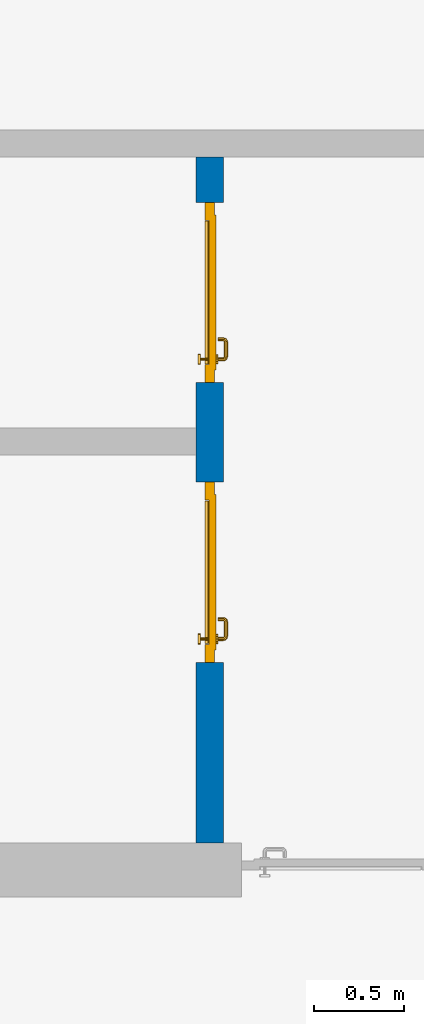
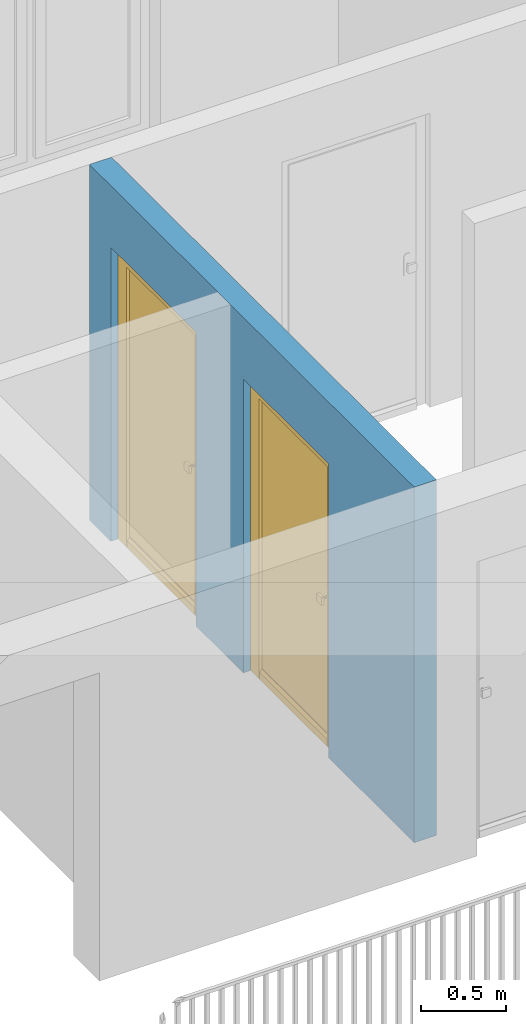
# One storey, part 18 of 54: 2 doors, 1 wall, 2 openings.
"""IFC4 building model written with IfcOpenShell, lengths in metres."""

from ifc_helpers import new_model, entity, si_unit, converted_unit, derived_unit, direction, frame, origin_with_axes, place, context, subcontext, project, spatial, polygons, source, transform, mapped, material, type_object, element, fill, save


model = new_model("IFC4")

# Units and contexts
model_context = context("Model", 3, precision=1e-05, world=origin_with_axes(), true_north=direction((0.0, 1.0)))
body_context = subcontext(model_context, "Body", "Model", "MODEL_VIEW")
ifc_project = project(units=[si_unit("LENGTHUNIT", "METRE"), si_unit("AREAUNIT", "SQUARE_METRE"), si_unit("VOLUMEUNIT", "CUBIC_METRE"), converted_unit("PLANEANGLEUNIT", "DEGREE", entity("IfcPlaneAngleMeasure", 0.0174532925199), si_unit("PLANEANGLEUNIT", "RADIAN"), dimensions=[0, 0, 0, 0, 0, 0, 0]), converted_unit("TIMEUNIT", "Year", entity("IfcTimeMeasure", 31556926.0), si_unit("TIMEUNIT", "SECOND"), dimensions=[0, 0, 1, 0, 0, 0, 0]), si_unit("MASSUNIT", "GRAM", prefix="KILO"), si_unit("THERMODYNAMICTEMPERATUREUNIT", "DEGREE_CELSIUS"), si_unit("LUMINOUSINTENSITYUNIT", "LUMEN"), si_unit("ENERGYUNIT", "JOULE", prefix="MEGA"), derived_unit("THERMALCONDUCTANCEUNIT", [(si_unit("POWERUNIT", "WATT"), 1), (si_unit("LENGTHUNIT", "METRE"), -1), (si_unit("THERMODYNAMICTEMPERATUREUNIT", "KELVIN"), -1)]), derived_unit("SPECIFICHEATCAPACITYUNIT", [(si_unit("ENERGYUNIT", "JOULE"), 1), (si_unit("MASSUNIT", "GRAM", prefix="KILO"), -1), (si_unit("THERMODYNAMICTEMPERATUREUNIT", "KELVIN"), -1)]), derived_unit("MASSDENSITYUNIT", [(si_unit("MASSUNIT", "GRAM", prefix="KILO"), 1), (si_unit("VOLUMEUNIT", "CUBIC_METRE"), -1)])], contexts=[model_context])

# Site, building, storey
site_placement = place(None, origin_with_axes())
site = spatial("IfcSite", under=ifc_project, at=site_placement, CompositionType="ELEMENT")
building_placement = place(site_placement, origin_with_axes())
building = spatial("IfcBuilding", under=site, at=building_placement, CompositionType="ELEMENT")
storey_placement = place(building_placement, frame((0.0, 0.0, 6.29), z_axis=(0.0, 0.0, 1.0), x_axis=(1.0, 0.0, 0.0)))
storey = spatial("IfcBuildingStorey", under=building, at=storey_placement, Name="2. Geschoss", CompositionType="ELEMENT", Elevation=6.29)

# Wall, openings, doors
ifc_material = material()
wall_type = type_object("IfcWallType", Name="150", PredefinedType="NOTDEFINED")
wall_placement = place(storey_placement, frame((1.3378006196, 1.37118776896, 0.0), z_axis=(0.0, 0.0, 1.0), x_axis=(0.0, 1.0, 0.0)))
wall = element("IfcWall", 1, at=wall_placement, inside=storey, type_object=wall_type, material=ifc_material, Name="Wand-002", PredefinedType="NOTDEFINED", context=body_context, shape_type="Tessellation", body=[
    polygons([(1.3, 0.0, 0.0), (1.3, 0.0, 2.1), (2.3, 0.0, 2.1), (2.3, 0.0, 0.0), (2.85, 0.0, 0.0), (2.85, 0.0, 2.1), (3.85, 0.0, 2.1), (3.85, 0.0, 0.0), (4.1, 0.0, 0.0), (4.1, 0.0, 2.54), (0.3, 0.0, 2.54), (0.3, 0.0, 0.0), (1.3, 0.1, 0.0), (1.3, 0.15, 0.0), (1.3, 0.15, 2.1), (2.3, 0.15, 2.1), (2.3, 0.1, 0.0), (2.3, 0.15, 0.0), (2.85, 0.15, 0.0), (2.85, 0.15, 2.1), (3.85, 0.15, 2.1), (3.85, 0.15, 0.0), (4.1, 0.15, 0.0), (4.1, 0.15, 2.54), (0.3, 0.15, 2.54), (0.3, 0.15, 0.0)], [[[1, 2, 3, 4, 5, 6, 7, 8, 9, 10, 11, 12]], [[2, 1, 13, 14, 15]], [[3, 2, 15, 16]], [[17, 4, 3, 16, 18]], [[4, 17, 18, 19, 5]], [[19, 20, 6, 5]], [[20, 21, 7, 6]], [[21, 22, 8, 7]], [[23, 9, 8, 22]], [[23, 24, 10, 9]], [[25, 11, 10, 24]], [[12, 11, 25, 26]], [[13, 1, 12, 26, 14]], [[19, 18, 16, 15, 14, 26, 25, 24, 23, 22, 21, 20]]], closed=True),
])
opening_1_placement = place(wall_placement, frame((3.35, 0.0, 0.0), z_axis=(0.0, 0.0, 1.0), x_axis=(1.0, 0.0, 0.0)))
opening_1 = element("IfcOpeningElement", 2, at=opening_1_placement, cuts=wall, context=body_context, identifier="Reference", shape_type="Tessellation", body=[
    polygons([(-0.5, 0.1, 0.0), (-0.5, 0.1, 2.1), (-0.5, 0.151, 2.1), (-0.5, 0.151, 0.0), (-0.5, -0.001, 0.0), (-0.5, -0.001, 2.1), (0.5, 0.1, 2.1), (0.5, 0.151, 2.1), (0.5, -0.001, 2.1), (0.5, 0.151, 0.0), (0.5, 0.1, 0.0), (0.5, -0.001, 0.0)], [[[1, 2, 3, 4]], [[2, 1, 5, 6]], [[7, 8, 3, 2, 6, 9]], [[8, 10, 4, 3]], [[1, 4, 10, 11, 12, 5]], [[6, 5, 12, 9]], [[7, 11, 10, 8]], [[11, 7, 9, 12]]], closed=True),
])
opening_2_placement = place(wall_placement, frame((1.8, 0.0, 0.0), z_axis=(0.0, 0.0, 1.0), x_axis=(1.0, 0.0, 0.0)))
opening_2 = element("IfcOpeningElement", 3, at=opening_2_placement, cuts=wall, context=body_context, identifier="Reference", shape_type="Tessellation", body=[
    polygons([(-0.5, 0.1, 0.0), (-0.5, 0.1, 2.1), (-0.5, 0.151, 2.1), (-0.5, 0.151, 0.0), (-0.5, -0.001, 0.0), (-0.5, -0.001, 2.1), (0.5, 0.1, 2.1), (0.5, 0.151, 2.1), (0.5, -0.001, 2.1), (0.5, 0.151, 0.0), (0.5, 0.1, 0.0), (0.5, -0.001, 0.0)], [[[1, 2, 3, 4]], [[2, 1, 5, 6]], [[7, 8, 3, 2, 6, 9]], [[8, 10, 4, 3]], [[1, 4, 10, 11, 12, 5]], [[6, 5, 12, 9]], [[7, 11, 10, 8]], [[11, 7, 9, 12]]], closed=True),
])
door_type = type_object("IfcDoorType", Name="Eingang 01 1-Fl 26", OperationType="SINGLE_SWING_LEFT", PredefinedType="DOOR")
shared_shape = source(origin_with_axes(), body_context, "Body", "Tessellation", [
    polygons([(-0.5, -0.05, 0.0), (-0.5, -0.05, 2.1), (-0.5, -0.03, 2.1), (-0.5, -0.03, 0.0), (-0.4, -0.05, 0.0), (-0.4, -0.05, 2.0), (-0.1301, -0.05, 2.0), (-0.0001, -0.05, 2.0), (0.4, -0.05, 2.0), (0.4, -0.05, 0.0), (0.5, -0.05, 0.0), (0.5, -0.05, 2.1), (0.5, -0.03, 2.1), (0.5, -0.03, 0.0), (0.4, -0.03, 0.0), (0.4, -0.03, 2.0), (-0.0001, -0.03, 2.0), (-0.1301, -0.03, 2.0), (-0.4, -0.03, 2.0), (-0.4, -0.03, 0.0)], [[[1, 2, 3, 4]], [[1, 5, 6, 7, 8, 9, 10, 11, 12, 2]], [[2, 12, 13, 3]], [[4, 3, 13, 14, 15, 16, 17, 18, 19, 20]], [[5, 1, 4, 20]], [[6, 5, 20, 19]], [[7, 6, 19, 18]], [[8, 7, 18, 17]], [[9, 8, 17, 16]], [[10, 9, 16, 15]], [[11, 10, 15, 14]], [[12, 11, 14, 13]]], closed=True),
    polygons([(-0.5, -0.03, 0.0), (-0.5, -0.03, 2.1), (-0.5, 0.0, 2.1), (-0.5, 0.0, 0.0), (-0.43, -0.03, 0.0), (-0.43, -0.03, 2.03), (-0.1001, -0.03, 2.03), (-0.0301, -0.03, 2.03), (0.43, -0.03, 2.03), (0.43, -0.03, 0.0), (0.5, -0.03, 0.0), (0.5, -0.03, 2.1), (0.5, 0.0, 2.1), (0.5, 0.0, 0.0), (0.43, 0.0, 0.0), (0.43, 0.0, 2.03), (-0.0301, 0.0, 2.03), (-0.1001, 0.0, 2.03), (-0.43, 0.0, 2.03), (-0.43, 0.0, 0.0)], [[[1, 2, 3, 4]], [[1, 5, 6, 7, 8, 9, 10, 11, 12, 2]], [[2, 12, 13, 3]], [[4, 3, 13, 14, 15, 16, 17, 18, 19, 20]], [[5, 1, 4, 20]], [[6, 5, 20, 19]], [[7, 6, 19, 18]], [[8, 7, 18, 17]], [[9, 8, 17, 16]], [[10, 9, 16, 15]], [[11, 10, 15, 14]], [[12, 11, 14, 13]]], closed=True),
    polygons([(-0.43, 0.01, 0.0), (-0.43, 0.01, 2.03), (0.43, 0.01, 2.03), (0.43, 0.01, 0.0), (-0.43, -0.03, 0.0), (-0.43, -0.03, 2.03), (0.43, -0.03, 2.03), (0.43, -0.03, 0.0)], [[[1, 2, 3, 4]], [[1, 5, 6, 2]], [[2, 6, 7, 3]], [[3, 7, 8, 4]], [[4, 8, 5, 1]], [[8, 7, 6, 5]]], closed=True),
    polygons([(-0.395, -0.05, 0.0), (0.395, -0.05, 0.0), (0.395, -0.05, 0.05), (-0.395, -0.05, 0.05), (-0.395, -0.03, 0.0), (0.395, -0.03, 0.0), (0.395, -0.03, 0.07), (0.395, -0.035, 0.07), (-0.395, -0.035, 0.07), (-0.395, -0.03, 0.07)], [[[1, 2, 3, 4]], [[5, 6, 2, 1]], [[2, 6, 7, 8, 3]], [[4, 3, 8, 9]], [[1, 4, 9, 10, 5]], [[10, 7, 6, 5]], [[9, 8, 7, 10]]], closed=True),
    polygons([(0.3835, 0.02, 1.0733826859), (0.37, 0.02, 1.077), (0.37, 0.0199, 1.077), (0.3835, 0.0199, 1.0733826859), (0.393382685902, 0.02, 1.0635), (0.397, 0.02, 1.05), (0.393382685902, 0.02, 1.0365), (0.3835, 0.02, 1.0266173141), (0.37, 0.02, 1.023), (0.3565, 0.02, 1.0266173141), (0.346617314098, 0.02, 1.0365), (0.343, 0.02, 1.05), (0.346617314098, 0.02, 1.0635), (0.3565, 0.02, 1.0733826859), (0.3565, 0.0199, 1.0733826859), (0.37, 0.0101, 1.077), (0.3835, 0.0101, 1.0733826859), (0.393382685902, 0.0199, 1.0635), (0.397, 0.0199, 1.05), (0.393382685902, 0.0199, 1.0365), (0.3835, 0.0199, 1.0266173141), (0.37, 0.0199, 1.023), (0.3565, 0.0199, 1.0266173141), (0.346617314098, 0.0199, 1.0365), (0.343, 0.0199, 1.05), (0.346617314098, 0.0199, 1.0635), (0.3565, 0.0101, 1.0733826859), (0.37, 0.01, 1.077), (0.3835, 0.01, 1.0733826859), (0.393382685902, 0.0101, 1.0635), (0.397, 0.0101, 1.05), (0.393382685902, 0.0101, 1.0365), (0.3835, 0.0101, 1.0266173141), (0.37, 0.0101, 1.023), (0.3565, 0.0101, 1.0266173141), (0.346617314098, 0.0101, 1.0365), (0.343, 0.0101, 1.05), (0.346617314098, 0.0101, 1.0635), (0.3565, 0.01, 1.0733826859), (0.346617314098, 0.01, 1.0635), (0.343, 0.01, 1.05), (0.346617314098, 0.01, 1.0365), (0.3565, 0.01, 1.0266173141), (0.37, 0.01, 1.023), (0.3835, 0.01, 1.0266173141), (0.393382685902, 0.01, 1.0365), (0.397, 0.01, 1.05), (0.393382685902, 0.01, 1.0635)], [[[1, 2, 3, 4]], [[2, 1, 5, 6, 7, 8, 9, 10, 11, 12, 13, 14]], [[2, 14, 15, 3]], [[4, 3, 16, 17]], [[5, 1, 4, 18]], [[6, 5, 18, 19]], [[7, 6, 19, 20]], [[8, 7, 20, 21]], [[9, 8, 21, 22]], [[10, 9, 22, 23]], [[11, 10, 23, 24]], [[12, 11, 24, 25]], [[13, 12, 25, 26]], [[14, 13, 26, 15]], [[3, 15, 27, 16]], [[17, 16, 28, 29]], [[18, 4, 17, 30]], [[19, 18, 30, 31]], [[20, 19, 31, 32]], [[21, 20, 32, 33]], [[22, 21, 33, 34]], [[23, 22, 34, 35]], [[24, 23, 35, 36]], [[25, 24, 36, 37]], [[26, 25, 37, 38]], [[15, 26, 38, 27]], [[16, 27, 39, 28]], [[28, 39, 40, 41, 42, 43, 44, 45, 46, 47, 48, 29]], [[30, 17, 29, 48]], [[31, 30, 48, 47]], [[32, 31, 47, 46]], [[33, 32, 46, 45]], [[34, 33, 45, 44]], [[35, 34, 44, 43]], [[36, 35, 43, 42]], [[37, 36, 42, 41]], [[38, 37, 41, 40]], [[27, 38, 40, 39]]], closed=True),
    polygons([(0.362532169224, 0.019, 0.959692280177), (0.363279754556, 0.019, 0.961639806549), (0.35705, 0.019, 0.972430057958), (0.347569942042, 0.019, 0.96295), (0.365, 0.019, 0.952886751346), (0.365, 0.019, 0.9544), (0.362532169224, 0.02, 0.959692280177), (0.363279754556, 0.02, 0.961639806549), (0.364624817685, 0.02, 0.965143815798), (0.364624817685, 0.019, 0.965143815798), (0.37, 0.019, 0.967425445323), (0.37, 0.019, 0.9759), (0.357, 0.019, 0.972516660498), (0.347483339502, 0.019, 0.963), (0.365, 0.019, 0.95), (0.3441, 0.019, 0.95), (0.365, 0.019, 0.947113248654), (0.365, 0.019, 0.941339745962), (0.365, 0.019, 0.9375), (0.365, 0.02, 0.9375), (0.365, 0.02, 0.941339745962), (0.365, 0.02, 0.947113248654), (0.365, 0.02, 0.95), (0.365, 0.02, 0.952886751346), (0.365, 0.02, 0.9544), (0.346703916638, 0.02, 0.96345), (0.35655, 0.02, 0.973296083362), (0.37, 0.02, 0.9769), (0.37, 0.02, 0.967425445323), (0.375375182315, 0.019, 0.965143815798), (0.376720245444, 0.019, 0.961639806549), (0.38295, 0.019, 0.972430057958), (0.37, 0.019, 0.976), (0.357, 0.0189, 0.972516660498), (0.347483339502, 0.0189, 0.963), (0.344, 0.019, 0.95), (0.347569942042, 0.019, 0.93705), (0.35705, 0.019, 0.927569942042), (0.37, 0.019, 0.9241), (0.37, 0.019, 0.9325), (0.366464466094, 0.019, 0.933964466094), (0.366464466094, 0.02, 0.933964466094), (0.37, 0.02, 0.9231), (0.35655, 0.02, 0.926703916638), (0.37, 0.02, 0.9325), (0.346703916638, 0.02, 0.93655), (0.3431, 0.02, 0.95), (0.346617314098, 0.02, 0.9635), (0.3565, 0.02, 0.973382685902), (0.37, 0.02, 0.977), (0.375375182315, 0.02, 0.965143815798), (0.38345, 0.02, 0.973296083362), (0.376720245444, 0.02, 0.961639806549), (0.377467830776, 0.02, 0.959692280177), (0.377467830776, 0.019, 0.959692280177), (0.375, 0.019, 0.9544), (0.375, 0.019, 0.952886751346), (0.392430057958, 0.019, 0.96295), (0.383, 0.019, 0.972516660498), (0.37, 0.0189, 0.976), (0.357, 0.0101, 0.972516660498), (0.347483339502, 0.0101, 0.963), (0.344, 0.0189, 0.95), (0.347483339502, 0.019, 0.937), (0.357, 0.019, 0.927483339502), (0.37, 0.019, 0.924), (0.38295, 0.019, 0.927569942042), (0.375, 0.019, 0.941339745962), (0.375, 0.019, 0.9375), (0.373535533906, 0.019, 0.933964466094), (0.37, 0.02, 0.923), (0.3565, 0.02, 0.926617314098), (0.38345, 0.02, 0.926703916638), (0.373535533906, 0.02, 0.933964466094), (0.375, 0.02, 0.9375), (0.375, 0.02, 0.941339745962), (0.346617314098, 0.02, 0.9365), (0.343, 0.02, 0.95), (0.346617314098, 0.0199, 0.9635), (0.3565, 0.0199, 0.973382685902), (0.37, 0.0199, 0.977), (0.3835, 0.02, 0.973382685902), (0.393296083362, 0.02, 0.96345), (0.375, 0.02, 0.952886751346), (0.375, 0.02, 0.9544), (0.375, 0.02, 0.95), (0.375, 0.02, 0.947113248654), (0.375, 0.019, 0.947113248654), (0.375, 0.019, 0.95), (0.3959, 0.019, 0.95), (0.392516660498, 0.019, 0.963), (0.383, 0.0189, 0.972516660498), (0.37, 0.0101, 0.976), (0.357, 0.01, 0.972516660498), (0.347483339502, 0.01, 0.963), (0.344, 0.0101, 0.95), (0.347483339502, 0.0189, 0.937), (0.357, 0.0189, 0.927483339502), (0.37, 0.0189, 0.924), (0.383, 0.019, 0.927483339502), (0.392430057958, 0.019, 0.93705), (0.37, 0.0199, 0.923), (0.3565, 0.0199, 0.926617314098), (0.3835, 0.02, 0.926617314098), (0.393296083362, 0.02, 0.93655), (0.346617314098, 0.0199, 0.9365), (0.343, 0.0199, 0.95), (0.346617314098, 0.0101, 0.9635), (0.3565, 0.0101, 0.973382685902), (0.37, 0.0101, 0.977), (0.3835, 0.0199, 0.973382685902), (0.393382685902, 0.02, 0.9635), (0.3969, 0.02, 0.95), (0.396, 0.019, 0.95), (0.392516660498, 0.0189, 0.963), (0.383, 0.0101, 0.972516660498), (0.37, 0.01, 0.976), (0.35695, 0.01, 0.972603263039), (0.347396736961, 0.01, 0.96305), (0.344, 0.01, 0.95), (0.347483339502, 0.0101, 0.937), (0.357, 0.0101, 0.927483339502), (0.37, 0.0101, 0.924), (0.383, 0.0189, 0.927483339502), (0.392516660498, 0.019, 0.937), (0.37, 0.0101, 0.923), (0.3565, 0.0101, 0.926617314098), (0.3835, 0.0199, 0.926617314098), (0.393382685902, 0.02, 0.9365), (0.346617314098, 0.0101, 0.9365), (0.343, 0.0101, 0.95), (0.346617314098, 0.01, 0.9635), (0.3565, 0.01, 0.973382685902), (0.37, 0.01, 0.977), (0.3835, 0.0101, 0.973382685902), (0.393382685902, 0.0199, 0.9635), (0.397, 0.02, 0.95), (0.396, 0.0189, 0.95), (0.392516660498, 0.0101, 0.963), (0.383, 0.01, 0.972516660498), (0.37, 0.01, 0.9761), (0.35655, 0.01, 0.973296083362), (0.346703916638, 0.01, 0.96345), (0.3439, 0.01, 0.95), (0.347483339502, 0.01, 0.937), (0.357, 0.01, 0.927483339502), (0.37, 0.01, 0.924), (0.383, 0.0101, 0.927483339502), (0.392516660498, 0.0189, 0.937), (0.37, 0.01, 0.923), (0.3565, 0.01, 0.926617314098), (0.3835, 0.0101, 0.926617314098), (0.393382685902, 0.0199, 0.9365), (0.346617314098, 0.01, 0.9365), (0.343, 0.01, 0.95), (0.37, 0.01, 0.9769), (0.3835, 0.01, 0.973382685902), (0.393382685902, 0.0101, 0.9635), (0.397, 0.0199, 0.95), (0.396, 0.0101, 0.95), (0.392516660498, 0.01, 0.963), (0.38305, 0.01, 0.972603263039), (0.3431, 0.01, 0.95), (0.347396736961, 0.01, 0.93695), (0.35695, 0.01, 0.927396736961), (0.37, 0.01, 0.9239), (0.383, 0.01, 0.927483339502), (0.392516660498, 0.0101, 0.937), (0.37, 0.01, 0.9231), (0.35655, 0.01, 0.926703916638), (0.3835, 0.01, 0.926617314098), (0.393382685902, 0.0101, 0.9365), (0.346703916638, 0.01, 0.93655), (0.38345, 0.01, 0.973296083362), (0.393382685902, 0.01, 0.9635), (0.397, 0.0101, 0.95), (0.396, 0.01, 0.95), (0.392603263039, 0.01, 0.96305), (0.38305, 0.01, 0.927396736961), (0.392516660498, 0.01, 0.937), (0.38345, 0.01, 0.926703916638), (0.393382685902, 0.01, 0.9365), (0.393296083362, 0.01, 0.96345), (0.397, 0.01, 0.95), (0.3961, 0.01, 0.95), (0.392603263039, 0.01, 0.93695), (0.393296083362, 0.01, 0.93655), (0.3969, 0.01, 0.95)], [[[1, 2, 3, 4, 5, 6]], [[1, 7, 8, 9, 10, 2]], [[10, 11, 12, 3, 2]], [[4, 3, 13, 14]], [[15, 5, 4, 16]], [[6, 5, 15, 17, 18, 19, 20, 21, 22, 23, 24, 25]], [[6, 25, 7, 1]], [[7, 25, 24, 26, 27, 8]], [[9, 8, 27, 28, 29]], [[10, 9, 29, 11]], [[30, 31, 32, 12, 11]], [[3, 12, 33, 13]], [[14, 13, 34, 35]], [[16, 4, 14, 36]], [[17, 15, 16, 37]], [[18, 17, 37, 38]], [[38, 39, 40, 41, 19, 18]], [[19, 41, 42, 20]], [[43, 44, 21, 20, 42, 45]], [[22, 21, 44, 46]], [[23, 22, 46, 47]], [[24, 23, 47, 26]], [[48, 49, 27, 26]], [[49, 50, 28, 27]], [[51, 29, 28, 52, 53]], [[11, 29, 51, 30]], [[30, 51, 53, 54, 55, 31]], [[55, 56, 57, 58, 32, 31]], [[12, 32, 59, 33]], [[13, 33, 60, 34]], [[35, 34, 61, 62]], [[36, 14, 35, 63]], [[37, 16, 36, 64]], [[38, 37, 64, 65]], [[39, 38, 65, 66]], [[39, 67, 68, 69, 70, 40]], [[41, 40, 45, 42]], [[71, 72, 44, 43]], [[73, 43, 45, 74, 75, 76]], [[72, 77, 46, 44]], [[77, 78, 47, 46]], [[78, 48, 26, 47]], [[79, 80, 49, 48]], [[80, 81, 50, 49]], [[50, 82, 52, 28]], [[54, 53, 52, 83, 84, 85]], [[55, 54, 85, 56]], [[85, 84, 86, 87, 76, 75, 69, 68, 88, 89, 57, 56]], [[57, 89, 90, 58]], [[32, 58, 91, 59]], [[33, 59, 92, 60]], [[34, 60, 93, 61]], [[62, 61, 94, 95]], [[63, 35, 62, 96]], [[64, 36, 63, 97]], [[65, 64, 97, 98]], [[66, 65, 98, 99]], [[67, 39, 66, 100]], [[88, 68, 67, 101]], [[70, 69, 75, 74]], [[40, 70, 74, 45]], [[102, 103, 72, 71]], [[104, 71, 43, 73]], [[76, 87, 105, 73]], [[103, 106, 77, 72]], [[106, 107, 78, 77]], [[107, 79, 48, 78]], [[108, 109, 80, 79]], [[109, 110, 81, 80]], [[81, 111, 82, 50]], [[82, 112, 83, 52]], [[86, 84, 83, 113]], [[87, 86, 113, 105]], [[89, 88, 101, 90]], [[58, 90, 114, 91]], [[59, 91, 115, 92]], [[60, 92, 116, 93]], [[61, 93, 117, 94]], [[95, 94, 118, 119]], [[96, 62, 95, 120]], [[97, 63, 96, 121]], [[98, 97, 121, 122]], [[99, 98, 122, 123]], [[100, 66, 99, 124]], [[101, 67, 100, 125]], [[126, 127, 103, 102]], [[128, 102, 71, 104]], [[129, 104, 73, 105]], [[127, 130, 106, 103]], [[130, 131, 107, 106]], [[131, 108, 79, 107]], [[132, 133, 109, 108]], [[133, 134, 110, 109]], [[110, 135, 111, 81]], [[111, 136, 112, 82]], [[112, 137, 113, 83]], [[137, 129, 105, 113]], [[90, 101, 125, 114]], [[91, 114, 138, 115]], [[92, 115, 139, 116]], [[93, 116, 140, 117]], [[94, 117, 141, 118]], [[119, 118, 142, 143]], [[120, 95, 119, 144]], [[121, 96, 120, 145]], [[122, 121, 145, 146]], [[123, 122, 146, 147]], [[124, 99, 123, 148]], [[125, 100, 124, 149]], [[150, 151, 127, 126]], [[152, 126, 102, 128]], [[153, 128, 104, 129]], [[151, 154, 130, 127]], [[154, 155, 131, 130]], [[155, 132, 108, 131]], [[143, 142, 133, 132]], [[142, 156, 134, 133]], [[134, 157, 135, 110]], [[135, 158, 136, 111]], [[136, 159, 137, 112]], [[159, 153, 129, 137]], [[114, 125, 149, 138]], [[115, 138, 160, 139]], [[116, 139, 161, 140]], [[117, 140, 162, 141]], [[118, 141, 156, 142]], [[144, 119, 143, 163]], [[145, 120, 144, 164]], [[146, 145, 164, 165]], [[147, 146, 165, 166]], [[148, 123, 147, 167]], [[149, 124, 148, 168]], [[169, 170, 151, 150]], [[171, 150, 126, 152]], [[172, 152, 128, 153]], [[170, 173, 154, 151]], [[173, 163, 155, 154]], [[163, 143, 132, 155]], [[156, 174, 157, 134]], [[157, 175, 158, 135]], [[158, 176, 159, 136]], [[176, 172, 153, 159]], [[138, 149, 168, 160]], [[139, 160, 177, 161]], [[140, 161, 178, 162]], [[141, 162, 174, 156]], [[164, 144, 163, 173]], [[165, 164, 173, 170]], [[166, 165, 170, 169]], [[167, 147, 166, 179]], [[168, 148, 167, 180]], [[181, 169, 150, 171]], [[182, 171, 152, 172]], [[174, 183, 175, 157]], [[175, 184, 176, 158]], [[184, 182, 172, 176]], [[160, 168, 180, 177]], [[161, 177, 185, 178]], [[162, 178, 183, 174]], [[179, 166, 169, 181]], [[180, 167, 179, 186]], [[187, 181, 171, 182]], [[183, 188, 184, 175]], [[188, 187, 182, 184]], [[177, 180, 186, 185]], [[178, 185, 188, 183]], [[186, 179, 181, 187]], [[185, 186, 187, 188]]], closed=True),
    polygons([(0.38, 0.02, 1.05), (0.377071067812, 0.02, 1.04292893219), (0.377071067812, 0.050696439392, 1.04292893219), (0.38, 0.0509849140336, 1.05), (0.37, 0.02, 1.04), (0.37, 0.05, 1.04), (0.375518993221, 0.0584992452783, 1.04292893219), (0.378277987014, 0.0596420579258, 1.05), (0.377071067812, 0.02, 1.05707106781), (0.377071067812, 0.050696439392, 1.05707106781), (0.362928932188, 0.02, 1.04292893219), (0.362928932188, 0.049303560608, 1.04292893219), (0.368858192988, 0.0557402514855, 1.04), (0.370704557509, 0.0657045575088, 1.04292893219), (0.372816199938, 0.0678161999379, 1.05), (0.375518993221, 0.0584992452783, 1.05707106781), (0.37, 0.02, 1.06), (0.37, 0.05, 1.06), (0.36, 0.02, 1.05), (0.36, 0.0490150859664, 1.05), (0.362197392755, 0.0529812576926, 1.04292893219), (0.365606601718, 0.0606066017178, 1.04), (0.363499245278, 0.0705189932208, 1.04292893219), (0.364642057926, 0.0732779870137, 1.05), (0.370704557509, 0.0657045575088, 1.05707106781), (0.368858192988, 0.0557402514855, 1.06), (0.362928932188, 0.02, 1.05707106781), (0.362928932188, 0.049303560608, 1.05707106781), (0.359438398962, 0.0518384450452, 1.05), (0.360508645927, 0.0555086459268, 1.04292893219), (0.360740251485, 0.0638581929877, 1.04), (0.355696439392, 0.0720710678119, 1.04292893219), (0.355984914034, 0.075, 1.05), (0.363499245278, 0.0705189932208, 1.05707106781), (0.365606601718, 0.0606066017178, 1.06), (0.362197392755, 0.0529812576926, 1.05707106781), (0.358397003498, 0.0533970034977, 1.05), (0.357981257693, 0.0571973927545, 1.04292893219), (0.355, 0.065, 1.04), (0.274303560608, 0.0720710678119, 1.04292893219), (0.274015085966, 0.075, 1.05), (0.355696439392, 0.0720710678119, 1.05707106781), (0.360740251485, 0.0638581929877, 1.06), (0.360508645927, 0.0555086459268, 1.05707106781), (0.356838445045, 0.0544383989617, 1.05), (0.354303560608, 0.0579289321881, 1.04292893219), (0.275, 0.065, 1.04), (0.266500754722, 0.0705189932208, 1.04292893219), (0.265357942074, 0.0732779870137, 1.05), (0.274303560608, 0.0720710678119, 1.05707106781), (0.355, 0.065, 1.06), (0.357981257693, 0.0571973927545, 1.05707106781), (0.354015085966, 0.055, 1.05), (0.275696439392, 0.0579289321881, 1.04292893219), (0.269259748515, 0.0638581929877, 1.04), (0.259295442491, 0.0657045575088, 1.04292893219), (0.257183800062, 0.0678161999379, 1.05), (0.266500754722, 0.0705189932208, 1.05707106781), (0.275, 0.065, 1.06), (0.354303560608, 0.0579289321881, 1.05707106781), (0.275984914034, 0.055, 1.05), (0.272018742307, 0.0571973927545, 1.04292893219), (0.264393398282, 0.0606066017178, 1.04), (0.254481006779, 0.0584992452783, 1.04292893219), (0.251722012986, 0.0596420579258, 1.05), (0.259295442491, 0.0657045575088, 1.05707106781), (0.269259748515, 0.0638581929877, 1.06), (0.275696439392, 0.0579289321881, 1.05707106781), (0.273161554955, 0.0544383989617, 1.05), (0.269491354073, 0.0555086459268, 1.04292893219), (0.261141807012, 0.0557402514855, 1.04), (0.252928932188, 0.050696439392, 1.04292893219), (0.25, 0.0509849140336, 1.05), (0.254481006779, 0.0584992452783, 1.05707106781), (0.264393398282, 0.0606066017178, 1.06), (0.272018742307, 0.0571973927545, 1.05707106781), (0.271602996502, 0.0533970034977, 1.05), (0.267802607245, 0.0529812576926, 1.04292893219), (0.26, 0.05, 1.04), (0.252928932188, 0.02, 1.04292893219), (0.25, 0.02, 1.05), (0.252928932188, 0.050696439392, 1.05707106781), (0.261141807012, 0.0557402514855, 1.06), (0.269491354073, 0.0555086459268, 1.05707106781), (0.270561601038, 0.0518384450452, 1.05), (0.267071067812, 0.049303560608, 1.04292893219), (0.26, 0.02, 1.04), (0.267071067812, 0.02, 1.04292893219), (0.27, 0.02, 1.05), (0.267071067812, 0.02, 1.05707106781), (0.26, 0.02, 1.06), (0.252928932188, 0.02, 1.05707106781), (0.26, 0.05, 1.06), (0.267802607245, 0.0529812576926, 1.05707106781), (0.27, 0.0490150859664, 1.05), (0.267071067812, 0.049303560608, 1.05707106781)], [[[1, 2, 3, 4]], [[2, 5, 6, 3]], [[4, 3, 7, 8]], [[9, 1, 4, 10]], [[5, 11, 12, 6]], [[3, 6, 13, 7]], [[8, 7, 14, 15]], [[10, 4, 8, 16]], [[17, 9, 10, 18]], [[11, 19, 20, 12]], [[6, 12, 21, 13]], [[7, 13, 22, 14]], [[15, 14, 23, 24]], [[16, 8, 15, 25]], [[18, 10, 16, 26]], [[27, 17, 18, 28]], [[19, 27, 28, 20]], [[12, 20, 29, 21]], [[13, 21, 30, 22]], [[14, 22, 31, 23]], [[24, 23, 32, 33]], [[25, 15, 24, 34]], [[26, 16, 25, 35]], [[28, 18, 26, 36]], [[20, 28, 36, 29]], [[21, 29, 37, 30]], [[22, 30, 38, 31]], [[23, 31, 39, 32]], [[33, 32, 40, 41]], [[34, 24, 33, 42]], [[35, 25, 34, 43]], [[36, 26, 35, 44]], [[29, 36, 44, 37]], [[30, 37, 45, 38]], [[31, 38, 46, 39]], [[32, 39, 47, 40]], [[41, 40, 48, 49]], [[42, 33, 41, 50]], [[43, 34, 42, 51]], [[44, 35, 43, 52]], [[37, 44, 52, 45]], [[38, 45, 53, 46]], [[39, 46, 54, 47]], [[40, 47, 55, 48]], [[49, 48, 56, 57]], [[50, 41, 49, 58]], [[51, 42, 50, 59]], [[52, 43, 51, 60]], [[45, 52, 60, 53]], [[46, 53, 61, 54]], [[47, 54, 62, 55]], [[48, 55, 63, 56]], [[57, 56, 64, 65]], [[58, 49, 57, 66]], [[59, 50, 58, 67]], [[60, 51, 59, 68]], [[53, 60, 68, 61]], [[54, 61, 69, 62]], [[55, 62, 70, 63]], [[56, 63, 71, 64]], [[65, 64, 72, 73]], [[66, 57, 65, 74]], [[67, 58, 66, 75]], [[68, 59, 67, 76]], [[61, 68, 76, 69]], [[62, 69, 77, 70]], [[63, 70, 78, 71]], [[64, 71, 79, 72]], [[73, 72, 80, 81]], [[74, 65, 73, 82]], [[75, 66, 74, 83]], [[76, 67, 75, 84]], [[69, 76, 84, 77]], [[70, 77, 85, 78]], [[71, 78, 86, 79]], [[72, 79, 87, 80]], [[81, 80, 87, 88, 89, 90, 91, 92]], [[82, 73, 81, 92]], [[83, 74, 82, 93]], [[84, 75, 83, 94]], [[77, 84, 94, 85]], [[78, 85, 95, 86]], [[79, 86, 88, 87]], [[86, 95, 89, 88]], [[95, 96, 90, 89]], [[96, 93, 91, 90]], [[93, 82, 92, 91]], [[94, 83, 93, 96]], [[85, 94, 96, 95]]], closed=False),
    polygons([(0.364696699141, -0.035, 1.04469669914), (0.3625, -0.035, 1.05), (0.364696699141, -0.035, 1.05530330086), (0.37, -0.035, 1.0575), (0.375303300859, -0.035, 1.05530330086), (0.3775, -0.035, 1.05), (0.375303300859, -0.035, 1.04469669914), (0.37, -0.035, 1.0425), (0.364696699141, -0.075, 1.04469669914), (0.3625, -0.075, 1.05), (0.364696699141, -0.075, 1.05530330086), (0.37, -0.075, 1.0575), (0.375303300859, -0.075, 1.05530330086), (0.3775, -0.075, 1.05), (0.375303300859, -0.075, 1.04469669914), (0.37, -0.075, 1.0425)], [[[1, 2, 3, 4, 5, 6, 7, 8]], [[1, 9, 10, 2]], [[2, 10, 11, 3]], [[3, 11, 12, 4]], [[4, 12, 13, 5]], [[5, 13, 14, 6]], [[6, 14, 15, 7]], [[7, 15, 16, 8]], [[8, 16, 9, 1]], [[9, 16, 15, 14, 13, 12, 11, 10]]], closed=True),
    polygons([(0.395, -0.03, 0.975), (0.395, -0.035, 0.975), (0.393096988313, -0.035, 0.965432914191), (0.393096988313, -0.03, 0.965432914191), (0.395, -0.03, 1.1), (0.395, -0.035, 1.1), (0.393096988313, -0.035, 1.10956708581), (0.38767766953, -0.035, 1.11767766953), (0.379567085809, -0.035, 1.12309698831), (0.37, -0.035, 1.125), (0.360432914191, -0.035, 1.12309698831), (0.35232233047, -0.035, 1.11767766953), (0.346903011687, -0.035, 1.10956708581), (0.345, -0.035, 1.1), (0.345, -0.035, 0.975), (0.346903011687, -0.035, 0.965432914191), (0.35232233047, -0.035, 0.95732233047), (0.360432914191, -0.035, 0.951903011687), (0.37, -0.035, 0.95), (0.379567085809, -0.035, 0.951903011687), (0.38767766953, -0.035, 0.95732233047), (0.38767766953, -0.03, 0.95732233047), (0.379567085809, -0.03, 0.951903011687), (0.37, -0.03, 0.95), (0.360432914191, -0.03, 0.951903011687), (0.35232233047, -0.03, 0.95732233047), (0.346903011687, -0.03, 0.965432914191), (0.345, -0.03, 0.975), (0.345, -0.03, 1.1), (0.346903011687, -0.03, 1.10956708581), (0.35232233047, -0.03, 1.11767766953), (0.360432914191, -0.03, 1.12309698831), (0.37, -0.03, 1.125), (0.379567085809, -0.03, 1.12309698831), (0.38767766953, -0.03, 1.11767766953), (0.393096988313, -0.03, 1.10956708581)], [[[1, 2, 3, 4]], [[5, 6, 2, 1]], [[2, 6, 7, 8, 9, 10, 11, 12, 13, 14, 15, 16, 17, 18, 19, 20, 21, 3]], [[4, 3, 21, 22]], [[1, 4, 22, 23, 24, 25, 26, 27, 28, 29, 30, 31, 32, 33, 34, 35, 36, 5]], [[36, 7, 6, 5]], [[35, 8, 7, 36]], [[34, 9, 8, 35]], [[33, 10, 9, 34]], [[32, 11, 10, 33]], [[31, 12, 11, 32]], [[30, 13, 12, 31]], [[29, 14, 13, 30]], [[28, 15, 14, 29]], [[27, 16, 15, 28]], [[26, 17, 16, 27]], [[25, 18, 17, 26]], [[24, 19, 18, 25]], [[23, 20, 19, 24]], [[22, 21, 20, 23]]], closed=True),
    polygons([(0.39, -0.075, 1.08), (0.39, -0.09, 1.08), (0.395, -0.09, 1.07866025404), (0.395, -0.075, 1.07866025404), (0.35, -0.075, 1.08), (0.35, -0.09, 1.08), (0.345, -0.09, 1.07866025404), (0.341339745962, -0.09, 1.075), (0.34, -0.09, 1.07), (0.34, -0.09, 1.03), (0.341339745962, -0.09, 1.025), (0.345, -0.09, 1.02133974596), (0.35, -0.09, 1.02), (0.39, -0.09, 1.02), (0.395, -0.09, 1.02133974596), (0.398660254038, -0.09, 1.025), (0.4, -0.09, 1.03), (0.4, -0.09, 1.07), (0.398660254038, -0.09, 1.075), (0.398660254038, -0.075, 1.075), (0.4, -0.075, 1.07), (0.4, -0.075, 1.03), (0.398660254038, -0.075, 1.025), (0.395, -0.075, 1.02133974596), (0.39, -0.075, 1.02), (0.35, -0.075, 1.02), (0.345, -0.075, 1.02133974596), (0.341339745962, -0.075, 1.025), (0.34, -0.075, 1.03), (0.34, -0.075, 1.07), (0.341339745962, -0.075, 1.075), (0.345, -0.075, 1.07866025404)], [[[1, 2, 3, 4]], [[5, 6, 2, 1]], [[2, 6, 7, 8, 9, 10, 11, 12, 13, 14, 15, 16, 17, 18, 19, 3]], [[4, 3, 19, 20]], [[1, 4, 20, 21, 22, 23, 24, 25, 26, 27, 28, 29, 30, 31, 32, 5]], [[32, 7, 6, 5]], [[31, 8, 7, 32]], [[30, 9, 8, 31]], [[29, 10, 9, 30]], [[28, 11, 10, 29]], [[27, 12, 11, 28]], [[26, 13, 12, 27]], [[25, 14, 13, 26]], [[24, 15, 14, 25]], [[23, 16, 15, 24]], [[22, 17, 16, 23]], [[21, 18, 17, 22]], [[20, 19, 18, 21]]], closed=True),
])
door_1_placement = place(opening_1_placement, frame((0.4, 0.0, 0.0), z_axis=(0.0, 0.0, 1.0), x_axis=(-1.0, 0.0, 0.0)))
door_1 = element("IfcDoor", 4, at=door_1_placement, inside=storey, type_object=door_type, OverallHeight=2.1, OverallWidth=1.0, PredefinedType="DOOR", context=body_context, shape_type="MappedRepresentation", body=[
    mapped(shared_shape, transform((0.4, -0.05, 0.0))),
])
fill(opening_1, door_1)
door_2_placement = place(opening_2_placement, frame((0.4, 0.0, 0.0), z_axis=(0.0, 0.0, 1.0), x_axis=(-1.0, 0.0, 0.0)))
door_2 = element("IfcDoor", 5, at=door_2_placement, inside=storey, type_object=door_type, OverallHeight=2.1, OverallWidth=1.0, PredefinedType="DOOR", context=body_context, shape_type="MappedRepresentation", body=[
    mapped(shared_shape, transform((0.4, -0.05, 0.0))),
])
fill(opening_2, door_2)

save(model, "model.ifc")
